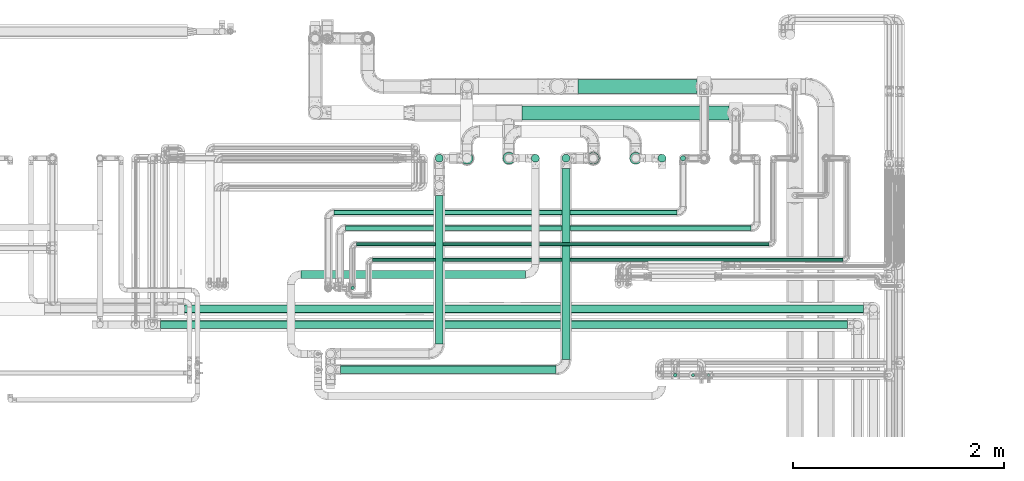
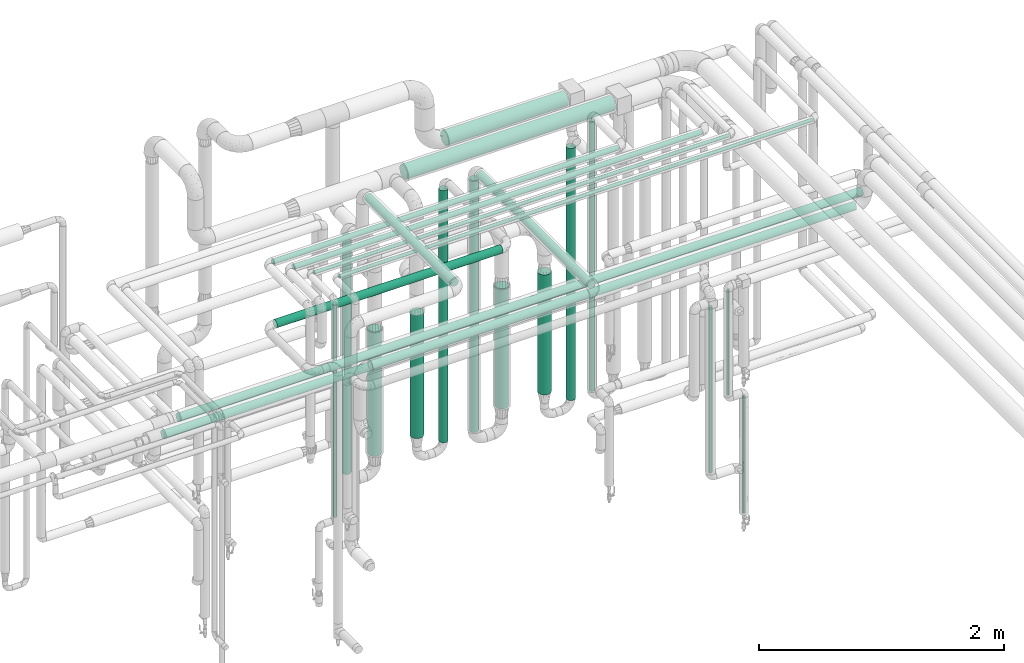
# One storey, part 542 of 827: 25 flow segments.
"""IFC2X3 building model written with IfcOpenShell, lengths in millimetres."""

from ifc_helpers import new_model, entity, si_unit, converted_unit, derived_unit, direction, frame, origin, origin_2d_with_axis, place, context, subcontext, project, spatial, circle, extrude, type_object, element, save


model = new_model("IFC2X3")

# Units and contexts
model_context = context("Model", 3, precision=0.01, world=origin(), true_north=direction((6.12303176911189e-17, 1.0)))
body_context = subcontext(model_context, "Body", "Model", "MODEL_VIEW")
ifc_project = project(units=[si_unit("LENGTHUNIT", "METRE", prefix="MILLI"), si_unit("AREAUNIT", "SQUARE_METRE"), si_unit("VOLUMEUNIT", "CUBIC_METRE"), converted_unit("PLANEANGLEUNIT", "DEGREE", entity("IfcRatioMeasure", 0.0174532925199433), si_unit("PLANEANGLEUNIT", "RADIAN"), dimensions=[0, 0, 0, 0, 0, 0, 0]), si_unit("MASSUNIT", "GRAM", prefix="KILO"), derived_unit("MASSDENSITYUNIT", [(si_unit("MASSUNIT", "GRAM", prefix="KILO"), 1), (si_unit("LENGTHUNIT", "METRE"), -3)]), derived_unit("MOMENTOFINERTIAUNIT", [(si_unit("LENGTHUNIT", "METRE"), 4)]), si_unit("TIMEUNIT", "SECOND"), si_unit("FREQUENCYUNIT", "HERTZ"), si_unit("THERMODYNAMICTEMPERATUREUNIT", "DEGREE_CELSIUS"), derived_unit("THERMALTRANSMITTANCEUNIT", [(si_unit("MASSUNIT", "GRAM", prefix="KILO"), 1), (si_unit("THERMODYNAMICTEMPERATUREUNIT", "KELVIN"), -1), (si_unit("TIMEUNIT", "SECOND"), -3)]), derived_unit("VOLUMETRICFLOWRATEUNIT", [(si_unit("LENGTHUNIT", "METRE"), 3), (si_unit("TIMEUNIT", "SECOND"), -1)]), derived_unit("MASSFLOWRATEUNIT", [(si_unit("MASSUNIT", "GRAM", prefix="KILO"), 1), (si_unit("TIMEUNIT", "SECOND"), -1)]), derived_unit("ROTATIONALFREQUENCYUNIT", [(si_unit("TIMEUNIT", "SECOND"), -1)]), si_unit("ELECTRICCURRENTUNIT", "AMPERE"), si_unit("ELECTRICVOLTAGEUNIT", "VOLT"), si_unit("POWERUNIT", "WATT"), si_unit("FORCEUNIT", "NEWTON", prefix="KILO"), si_unit("ILLUMINANCEUNIT", "LUX"), si_unit("LUMINOUSFLUXUNIT", "LUMEN"), si_unit("LUMINOUSINTENSITYUNIT", "CANDELA"), derived_unit("USERDEFINED", [(si_unit("MASSUNIT", "GRAM", prefix="KILO"), -1), (si_unit("LENGTHUNIT", "METRE"), -2), (si_unit("TIMEUNIT", "SECOND"), 3), (si_unit("LUMINOUSFLUXUNIT", "LUMEN"), 1)]), derived_unit("LINEARVELOCITYUNIT", [(si_unit("LENGTHUNIT", "METRE"), 1), (si_unit("TIMEUNIT", "SECOND"), -1)]), si_unit("PRESSUREUNIT", "PASCAL"), derived_unit("USERDEFINED", [(si_unit("LENGTHUNIT", "METRE"), -2), (si_unit("MASSUNIT", "GRAM", prefix="KILO"), 1), (si_unit("TIMEUNIT", "SECOND"), -2)]), derived_unit("LINEARFORCEUNIT", [(si_unit("MASSUNIT", "GRAM", prefix="KILO"), 1), (si_unit("LENGTHUNIT", "METRE"), 1), (si_unit("TIMEUNIT", "SECOND"), -2), (si_unit("LENGTHUNIT", "METRE"), -1)]), derived_unit("PLANARFORCEUNIT", [(si_unit("MASSUNIT", "GRAM", prefix="KILO"), 1), (si_unit("LENGTHUNIT", "METRE"), 1), (si_unit("TIMEUNIT", "SECOND"), -2), (si_unit("LENGTHUNIT", "METRE"), -2)])], contexts=[model_context])

# Site, building, storey
site_placement = place(None, origin())
site = spatial("IfcSite", under=ifc_project, at=site_placement, CompositionType="ELEMENT")
building_placement = place(site_placement, origin())
building = spatial("IfcBuilding", under=site, at=building_placement, CompositionType="ELEMENT")
storey_placement = place(building_placement, frame((0.0, 0.0, 28200.0)))
storey = spatial("IfcBuildingStorey", under=building, at=storey_placement, Name="08", CompositionType="ELEMENT", Elevation=28200.0)

# Flow segments
pipe_segment_type_1 = type_object("IfcPipeSegmentType", PredefinedType="NOTDEFINED")
flow_segment_1_placement = place(storey_placement, frame((58101.05, 18112.0, 2831.9)))
element("IfcFlowSegment", 1, at=flow_segment_1_placement, inside=storey, type_object=pipe_segment_type_1, context=body_context, shape_type="SweptSolid", body=[
    extrude(circle(Radius=66.5, at=origin_2d_with_axis()), frame((0.0, 68.1, 68.1), z_axis=(1.0, 0.0, 0.0), x_axis=(0.0, 1.0, 0.0)), (0.0, 0.0, 1.0), 1131.84247335702),
])
flow_segment_2_placement = place(storey_placement, frame((57571.89, 17862.0, 2831.87)))
element("IfcFlowSegment", 2, at=flow_segment_2_placement, inside=storey, type_object=pipe_segment_type_1, context=body_context, shape_type="SweptSolid", body=[
    extrude(circle(Radius=66.5, at=origin_2d_with_axis()), frame((0.0, 68.1, 68.1), z_axis=(1.0, 0.0, 0.0), x_axis=(0.0, 1.0, 0.0)), (0.0, 0.0, 1.0), 1959.7835585026),
])
pipe_segment_type_2 = type_object("IfcPipeSegmentType", PredefinedType="NOTDEFINED")
flow_segment_3_placement = place(storey_placement, frame((59177.64, 15429.21, 1622.15)))
element("IfcFlowSegment", 3, at=flow_segment_3_placement, inside=storey, type_object=pipe_segment_type_2, context=body_context, shape_type="SweptSolid", body=[
    extrude(circle(Radius=13.4, at=origin_2d_with_axis()), frame((15.0, 15.0, 0.0), z_axis=(0.0, 0.0, 1.0), x_axis=(-1.0, 0.0, 0.0)), (0.0, 0.0, 1.0), 1048.75110334734),
])
flow_segment_4_placement = place(storey_placement, frame((59006.79, 15425.86, 908.51)))
element("IfcFlowSegment", 4, at=flow_segment_4_placement, inside=storey, type_object=pipe_segment_type_2, context=body_context, shape_type="SweptSolid", body=[
    extrude(circle(Radius=16.75, at=origin_2d_with_axis()), frame((18.35, 18.35, 0.0)), (0.0, 0.0, 1.0), 1653.487023342),
])
flow_segment_5_placement = place(storey_placement, frame((59325.47, 15429.21, 395.55)))
element("IfcFlowSegment", 5, at=flow_segment_5_placement, inside=storey, type_object=pipe_segment_type_2, context=body_context, shape_type="SweptSolid", body=[
    extrude(circle(Radius=13.4, at=origin_2d_with_axis()), frame((15.0, 15.0, 0.0)), (0.0, 0.0, 1.0), 1168.40000000002),
])
flow_segment_6_placement = place(storey_placement, frame((54374.79, 16033.03, 2660.69)))
element("IfcFlowSegment", 6, at=flow_segment_6_placement, inside=storey, type_object=pipe_segment_type_2, context=body_context, shape_type="SweptSolid", body=[
    extrude(circle(Radius=37.75, at=origin_2d_with_axis()), frame((0.0, 39.35, 39.35), z_axis=(1.0, 0.0, 0.0), x_axis=(0.0, -1.0, 0.0)), (0.0, 0.0, 1.0), 6433.31549000002),
])
flow_segment_7_placement = place(storey_placement, frame((59072.54, 17474.4, 457.0)))
element("IfcFlowSegment", 7, at=flow_segment_7_placement, inside=storey, type_object=pipe_segment_type_2, context=body_context, shape_type="SweptSolid", body=[
    extrude(circle(Radius=24.0, at=origin_2d_with_axis()), frame((25.6, 25.6, 0.0)), (0.0, 0.0, 1.0), 2685.99999999999),
])
flow_segment_8_placement = place(storey_placement, frame((57948.54, 17460.65, 445.0)))
element("IfcFlowSegment", 8, at=flow_segment_8_placement, inside=storey, type_object=pipe_segment_type_2, context=body_context, shape_type="SweptSolid", body=[
    extrude(circle(Radius=37.75, at=origin_2d_with_axis()), frame((39.35, 39.35, 0.0), z_axis=(0.0, 0.0, 1.0), x_axis=(-1.0, 0.0, 0.0)), (0.0, 0.0, 1.0), 2509.99999999998),
])
flow_segment_9_placement = place(storey_placement, frame((56748.04, 17460.65, 447.5)))
element("IfcFlowSegment", 9, at=flow_segment_9_placement, inside=storey, type_object=pipe_segment_type_2, context=body_context, shape_type="SweptSolid", body=[
    extrude(circle(Radius=37.75, at=origin_2d_with_axis()), frame((39.35, 39.35, 0.0), z_axis=(0.0, 0.0, 1.0), x_axis=(-1.0, 0.0, 0.0)), (0.0, 0.0, 1.0), 2357.49999999998),
])
for number, where in (
    (10, (58858.57, 17460.65, 445.0)),
    (11, (57658.79, 17460.65, 445.0)),
):
    element("IfcFlowSegment", number, at=place(storey_placement, frame(where)), inside=storey, type_object=pipe_segment_type_2, context=body_context, shape_type="SweptSolid", body=[
        extrude(circle(Radius=37.75, at=origin_2d_with_axis()), frame((39.35, 39.35, 0.0)), (0.0, 0.0, 1.0), 2509.99999999998),
    ])
flow_segment_10_placement = place(storey_placement, frame((55900.13, 16812.34, 3174.4)))
element("IfcFlowSegment", 12, at=flow_segment_10_placement, inside=storey, type_object=pipe_segment_type_2, context=body_context, shape_type="SweptSolid", body=[
    extrude(circle(Radius=24.0, at=origin_2d_with_axis()), frame((0.0, 25.6, 25.6), z_axis=(1.0, 0.0, 0.0), x_axis=(0.0, 1.0, 0.0)), (0.0, 0.0, 1.0), 3841.0),
])
flow_segment_11_placement = place(storey_placement, frame((56003.36, 16667.35, 3181.65)))
element("IfcFlowSegment", 13, at=flow_segment_11_placement, inside=storey, type_object=pipe_segment_type_2, context=body_context, shape_type="SweptSolid", body=[
    extrude(circle(Radius=16.75, at=origin_2d_with_axis()), frame((0.0, 18.35, 18.35), z_axis=(1.0, 0.0, 0.0), x_axis=(0.0, -1.0, 0.0)), (0.0, 0.0, 1.0), 3911.77267000001),
])
flow_segment_12_placement = place(storey_placement, frame((55791.18, 16960.1, 3174.4)))
element("IfcFlowSegment", 14, at=flow_segment_12_placement, inside=storey, type_object=pipe_segment_type_2, context=body_context, shape_type="SweptSolid", body=[
    extrude(circle(Radius=24.0, at=origin_2d_with_axis()), frame((0.0, 25.6, 25.6), z_axis=(1.0, 0.0, 0.0), x_axis=(0.0, 1.0, 0.0)), (0.0, 0.0, 1.0), 3249.95491),
])
flow_segment_13_placement = place(storey_placement, frame((57948.54, 15591.2, 3010.65)))
element("IfcFlowSegment", 15, at=flow_segment_13_placement, inside=storey, type_object=pipe_segment_type_2, context=body_context, shape_type="SweptSolid", body=[
    extrude(circle(Radius=37.75, at=origin_2d_with_axis()), frame((39.35, 0.0, 39.35), z_axis=(0.0, 1.0, 0.0), x_axis=(-1.0, 0.0, 0.0)), (0.0, 0.0, 1.0), 1813.79588635602),
])
flow_segment_14_placement = place(storey_placement, frame((55850.84, 15456.86, 3010.65)))
element("IfcFlowSegment", 16, at=flow_segment_14_placement, inside=storey, type_object=pipe_segment_type_2, context=body_context, shape_type="SweptSolid", body=[
    extrude(circle(Radius=37.75, at=origin_2d_with_axis()), frame((0.0, 39.35, 39.35), z_axis=(1.0, 0.0, 0.0), x_axis=(0.0, 1.0, 0.0)), (0.0, 0.0, 1.0), 2042.04196819739),
])
flow_segment_15_placement = place(storey_placement, frame((55476.84, 16359.27, 3010.65)))
element("IfcFlowSegment", 17, at=flow_segment_15_placement, inside=storey, type_object=pipe_segment_type_2, context=body_context, shape_type="SweptSolid", body=[
    extrude(circle(Radius=37.75, at=origin_2d_with_axis()), frame((0.0, 39.35, 39.35), z_axis=(1.0, 0.0, 0.0), x_axis=(0.0, 1.0, 0.0)), (0.0, 0.0, 1.0), 2126.28738999999),
])
flow_segment_16_placement = place(storey_placement, frame((56748.04, 15741.2, 3360.65)))
element("IfcFlowSegment", 18, at=flow_segment_16_placement, inside=storey, type_object=pipe_segment_type_2, context=body_context, shape_type="SweptSolid", body=[
    extrude(circle(Radius=37.75, at=origin_2d_with_axis()), frame((39.35, 0.0, 39.35), z_axis=(0.0, 1.0, 0.0), x_axis=(-1.0, 0.0, 0.0)), (0.0, 0.0, 1.0), 1403.79588635601),
])
flow_segment_17_placement = place(storey_placement, frame((56156.13, 16517.35, 3181.65)))
element("IfcFlowSegment", 19, at=flow_segment_17_placement, inside=storey, type_object=pipe_segment_type_2, context=body_context, shape_type="SweptSolid", body=[
    extrude(circle(Radius=16.75, at=origin_2d_with_axis()), frame((0.0, 18.35, 18.35), z_axis=(1.0, 0.0, 0.0), x_axis=(0.0, 1.0, 0.0)), (0.0, 0.0, 1.0), 4459.00000000002),
])
flow_segment_18_placement = place(storey_placement, frame((55947.01, 16252.09, 1038.0)))
element("IfcFlowSegment", 20, at=flow_segment_18_placement, inside=storey, type_object=pipe_segment_type_2, context=body_context, shape_type="SweptSolid", body=[
    extrude(circle(Radius=16.75, at=origin_2d_with_axis()), frame((18.35, 18.35, 0.0)), (0.0, 0.0, 1.0), 2124.0),
])
flow_segment_19_placement = place(storey_placement, frame((54145.79, 15883.03, 2660.65)))
element("IfcFlowSegment", 21, at=flow_segment_19_placement, inside=storey, type_object=pipe_segment_type_2, context=body_context, shape_type="SweptSolid", body=[
    extrude(circle(Radius=37.75, at=origin_2d_with_axis()), frame((0.0, 39.35, 39.35), z_axis=(1.0, 0.0, 0.0), x_axis=(0.0, 1.0, 0.0)), (0.0, 0.0, 1.0), 6512.31549000001),
])
flow_segment_20_placement = place(storey_placement, frame((58188.97, 17441.4, 602.0)))
element("IfcFlowSegment", 22, at=flow_segment_20_placement, inside=storey, type_object=pipe_segment_type_2, context=body_context, shape_type="SweptSolid", body=[
    extrude(circle(Radius=57.0, at=origin_2d_with_axis()), frame((58.6, 58.6, 0.0)), (0.0, 0.0, 1.0), 1198.45277752717),
])
flow_segment_21_placement = place(storey_placement, frame((58590.79, 17441.4, 602.0)))
element("IfcFlowSegment", 23, at=flow_segment_21_placement, inside=storey, type_object=pipe_segment_type_2, context=body_context, shape_type="SweptSolid", body=[
    extrude(circle(Radius=57.0, at=origin_2d_with_axis()), frame((58.6, 58.6, 0.0)), (0.0, 0.0, 1.0), 1194.16926665745),
])
flow_segment_22_placement = place(storey_placement, frame((57389.29, 17441.4, 589.0)))
element("IfcFlowSegment", 24, at=flow_segment_22_placement, inside=storey, type_object=pipe_segment_type_2, context=body_context, shape_type="SweptSolid", body=[
    extrude(circle(Radius=57.0, at=origin_2d_with_axis()), frame((58.6, 58.6, 0.0)), (0.0, 0.0, 1.0), 1224.45277752718),
])
flow_segment_23_placement = place(storey_placement, frame((56991.47, 17441.4, 549.5)))
element("IfcFlowSegment", 25, at=flow_segment_23_placement, inside=storey, type_object=pipe_segment_type_2, context=body_context, shape_type="SweptSolid", body=[
    extrude(circle(Radius=57.0, at=origin_2d_with_axis()), frame((58.6, 58.6, 0.0)), (0.0, 0.0, 1.0), 1241.2431888057),
])

save(model, "model.ifc")
